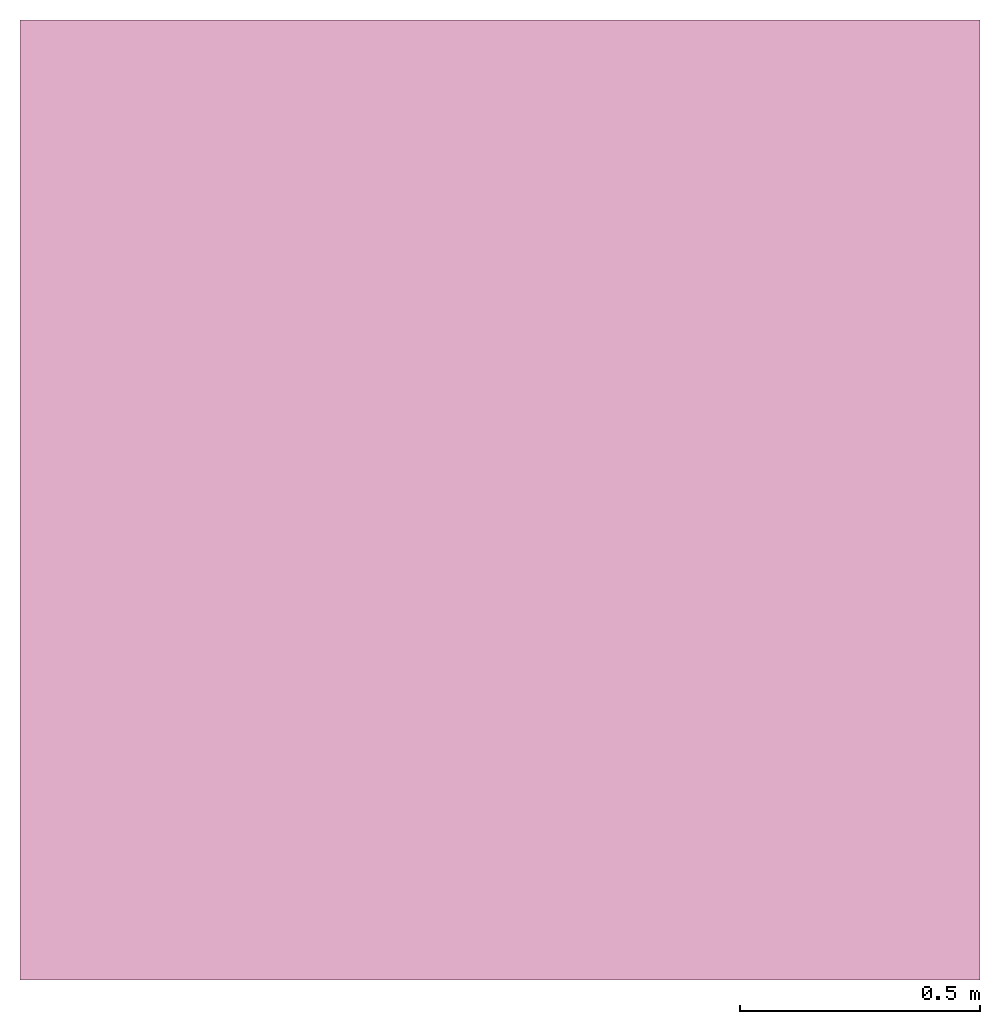
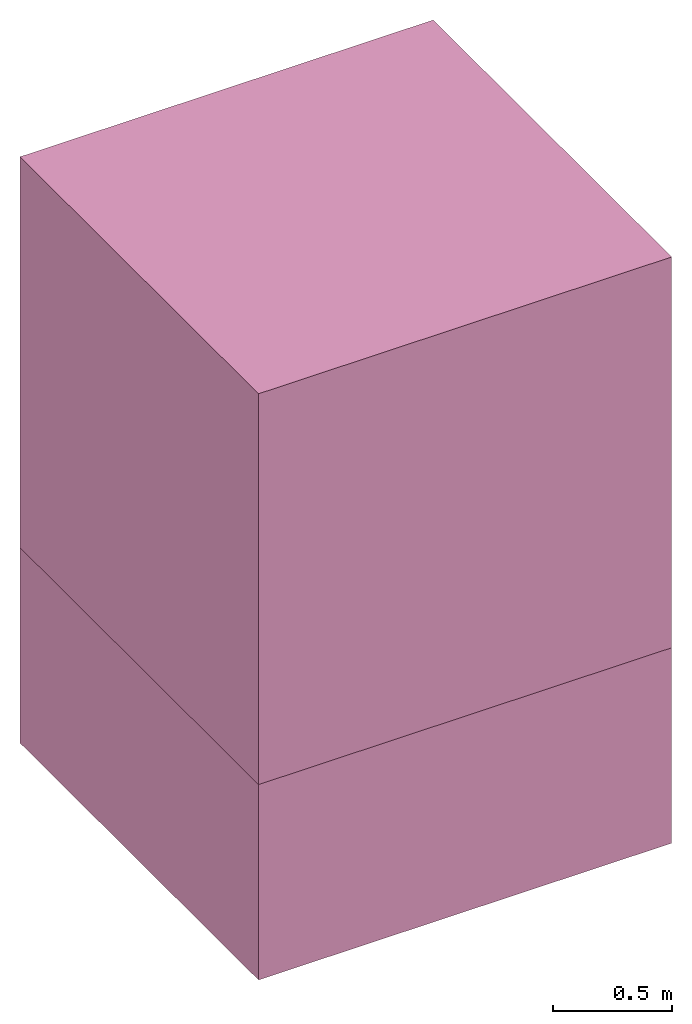
# One storey: 2 furnishings.
"""IFC2X3 building model written with IfcOpenShell, lengths in metres."""

from ifc_helpers import new_model, entity, si_unit, converted_unit, frame, frame_2d, origin_with_axes, place, context, project, spatial, rectangle, extrude, faceted_brep, shape, material, element, save


model = new_model("IFC2X3")

# Units and contexts
model_context = context("Model", 3, precision=1e-05, world=origin_with_axes())
plan_context = context("Plan", 2, precision=1e-05, world=frame_2d((0.0, 0.0, 0.0), x_axis=(1.0, 0.0, 0.0)))
ifc_project = project(units=[si_unit("VOLUMEUNIT", "CUBIC_METRE"), si_unit("LENGTHUNIT", "METRE"), converted_unit("PLANEANGLEUNIT", "degree", entity("IfcReal", 0.0174532925199433), si_unit("PLANEANGLEUNIT", "RADIAN"), dimensions=[0, 0, 0, 0, 0, 0, 0]), si_unit("AREAUNIT", "SQUARE_METRE")], contexts=[model_context, plan_context])

# Site, building, storey
site_placement = place(None, origin_with_axes())
site = spatial("IfcSite", under=ifc_project, at=site_placement, CompositionType="ELEMENT")
building_placement = place(site_placement, origin_with_axes())
building = spatial("IfcBuilding", under=site, at=building_placement, Name="Building", CompositionType="ELEMENT")
storey_placement = place(building_placement, origin_with_axes())
storey = spatial("IfcBuildingStorey", under=building, at=storey_placement, Name="Plan 1", CompositionType="ELEMENT")

# Furnishings
furnishing_1_placement = place(storey_placement, origin_with_axes())
element("IfcFurnishingElement", 1, at=furnishing_1_placement, inside=storey, Name="Cube", shapes=[
    shape(model_context, None, "SweptSolid", [extrude(rectangle(XDim=2.0, YDim=2.0, at=frame_2d((0.0, 0.0, 0.0))), frame((0.0, 0.0, 0.0), z_axis=(0.0, 0.0, -1.0), x_axis=(-1.0, 0.0, 0.0)), (0.0, 0.0, -1.0), 2.0)]),
])
ifc_material = material(Name="Plastic")
furnishing_2_placement = place(storey_placement, origin_with_axes())
element("IfcFurnishingElement", 2, at=furnishing_2_placement, inside=storey, material=ifc_material, Name="Cube", shapes=[
    shape(model_context, None, "Brep", [faceted_brep([(1.0, 1.0, -1.0), (1.0, -1.0, -1.0), (-1.0, -1.0, -1.0), (-1.0, 1.0, -1.0), (-1.0, -1.0, 1.0), (1.0, -1.0, 1.0), (1.0, 1.0, 1.0), (-1.0, 1.0, 1.0)], [[[0, 1, 2, 3]], [[4, 5, 6, 7]], [[7, 3, 2, 4]], [[5, 4, 2, 1]], [[3, 7, 6, 0]], [[6, 5, 1, 0]]])]),
])

save(model, "model.ifc")
